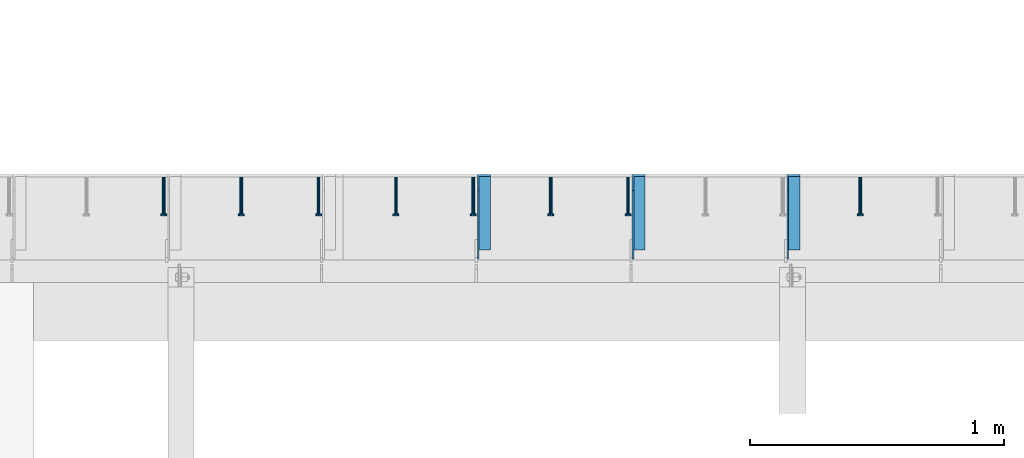
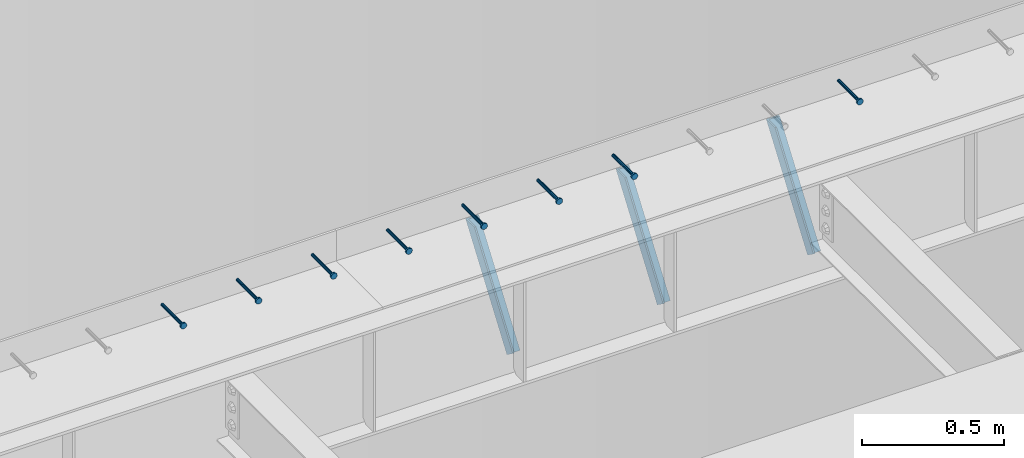
# One storey, part 1356 of 1763: 8 beams, 3 members, 9 elements without a shape of their own.
"""IFC2X3 building model written with IfcOpenShell, lengths in millimetres."""

from ifc_helpers import new_model, si_unit, frame, origin_with_axes, place, context, subcontext, project, spatial, faceted_brep, material, type_object, element, aggregate, save


model = new_model("IFC2X3")

# Units and contexts
model_context = context("Model", 3, precision=1e-05, world=origin_with_axes())
body_context = subcontext(model_context, "Body", "Model", "MODEL_VIEW")
ifc_project = project(units=[si_unit("LENGTHUNIT", "METRE", prefix="MILLI"), si_unit("AREAUNIT", "SQUARE_METRE"), si_unit("VOLUMEUNIT", "CUBIC_METRE"), si_unit("MASSUNIT", "GRAM", prefix="KILO"), si_unit("TIMEUNIT", "SECOND"), si_unit("PLANEANGLEUNIT", "RADIAN"), si_unit("SOLIDANGLEUNIT", "STERADIAN"), si_unit("THERMODYNAMICTEMPERATUREUNIT", "DEGREE_CELSIUS"), si_unit("LUMINOUSINTENSITYUNIT", "LUMEN")], contexts=[model_context])

# Site, building, storey
site_placement = place(None, origin_with_axes())
site = spatial("IfcSite", under=ifc_project, at=site_placement, CompositionType="ELEMENT")
building_placement = place(site_placement, origin_with_axes())
building = spatial("IfcBuilding", under=site, at=building_placement, Name="Undefined", CompositionType="ELEMENT")
storey_placement = place(building_placement, origin_with_axes())
storey = spatial("IfcBuildingStorey", under=building, at=storey_placement, Name="Undefined", CompositionType="ELEMENT", Elevation=0.0)

# Assembly, beam
assembly_1_placement = place(storey_placement, origin_with_axes())
assembly_1 = element("IfcElementAssembly", 1, at=assembly_1_placement, inside=storey, Name="HEADED STUD ANCHOR", AssemblyPlace="NOTDEFINED", PredefinedType="RIGID_FRAME")
ifc_material_1 = material(Name="STEEL/A108")
beam_type = type_object("IfcBeamType", PredefinedType="NOTDEFINED")
beam_1_placement = place(assembly_1_placement, frame((-44317.6747736983, 53984.5250183106, 5264.23140606069), z_axis=(0.0, 0.0, 1.0), x_axis=(0.0, -1.0, 0.0)))
beam_1 = element("IfcBeam", 2, at=beam_1_placement, type_object=beam_type, material=ifc_material_1, Name="HEADED STUD ANCHOR", context=body_context, shape_type="Brep", body=[
    faceted_brep([(0.0, -3.1800000667572, 5.5), (0.0, -5.5, 3.1800000667572), (141.732000000002, -5.5, 3.1800000667572), (141.732000000002, -3.1800000667572, 5.5), (0.0, -6.34999999999491, 1.45519152283669e-11), (141.732000000002, -6.34999990463257, 0.0), (0.0, -5.5, -3.1800000667572), (141.732000000002, -5.5, -3.1800000667572), (0.0, -3.1800000667572, -5.5), (141.732000000002, -3.1800000667572, -5.5), (0.0, 0.0, -6.34999990463257), (141.732000000002, 0.0, -6.34999990463257), (0.0, 3.1800000667572, -5.5), (141.732000000002, 3.1800000667572, -5.5), (0.0, 5.5, -3.1800000667572), (141.732000000002, 5.5, -3.1800000667572), (0.0, 6.34999999999491, -2.91038304567337e-11), (141.732000000002, 6.34999990463257, 0.0), (0.0, 5.5, 3.1800000667572), (141.732000000002, 5.5, 3.1800000667572), (0.0, 3.1800000667572, 5.5), (141.732000000002, 3.1800000667572, 5.5), (0.0, 0.0, 6.34999990463257), (141.732000000002, 0.0, 6.34999990463257), (144.780000000001, -10.9899997711182, 6.34999990463257), (144.780000000001, -6.34000015258789, 10.9899997711182), (144.780000000001, -12.6999998092651, 0.0), (144.780000000001, -10.9899997711182, -6.34999990463257), (144.780000000001, -6.34000015258789, -10.9899997711182), (144.780000000001, 0.0, -12.6899995803833), (144.780000000001, 6.34000015258789, -10.9899997711182), (144.780000000001, 10.9899997711182, -6.34999990463257), (144.780000000001, 12.6999998092651, 0.0), (144.780000000001, 10.9899997711182, 6.34999990463257), (144.780000000001, 6.34000015258789, 10.9899997711182), (144.780000000001, 0.0, 12.6899995803833), (152.400000000001, -10.9899997711182, 6.34999990463257), (152.400000000001, -6.34000015258789, 10.9899997711182), (152.400000000001, -12.6999998092651, 0.0), (152.400000000001, -10.9899997711182, -6.34999990463257), (152.400000000001, -6.34000015258789, -10.9899997711182), (152.400000000001, 0.0, -12.6899995803833), (152.400000000001, 6.34000015258789, -10.9899997711182), (152.400000000001, 10.9899997711182, -6.34999990463257), (152.400000000001, 12.6999998092651, 0.0), (152.400000000001, 10.9899997711182, 6.34999990463257), (152.400000000001, 6.34000015258789, 10.9899997711182), (152.400000000001, 0.0, 12.6899995803833)], [[[0, 1, 2, 3]], [[1, 4, 5, 2]], [[4, 6, 7, 5]], [[6, 8, 9, 7]], [[8, 10, 11, 9]], [[10, 12, 13, 11]], [[12, 14, 15, 13]], [[14, 16, 17, 15]], [[16, 18, 19, 17]], [[18, 20, 21, 19]], [[20, 22, 23, 21]], [[22, 0, 3, 23]], [[22, 20, 18, 16, 14, 12, 10, 8, 6, 4, 1, 0]], [[3, 2, 24, 25]], [[2, 5, 26, 24]], [[5, 7, 27, 26]], [[7, 9, 28, 27]], [[9, 11, 29, 28]], [[11, 13, 30, 29]], [[13, 15, 31, 30]], [[15, 17, 32, 31]], [[17, 19, 33, 32]], [[19, 21, 34, 33]], [[21, 23, 35, 34]], [[23, 3, 25, 35]], [[25, 24, 36, 37]], [[24, 26, 38, 36]], [[26, 27, 39, 38]], [[27, 28, 40, 39]], [[28, 29, 41, 40]], [[29, 30, 42, 41]], [[30, 31, 43, 42]], [[31, 32, 44, 43]], [[32, 33, 45, 44]], [[33, 34, 46, 45]], [[34, 35, 47, 46]], [[35, 25, 37, 47]], [[38, 39, 40, 41, 42, 43, 44, 45, 46, 47, 37, 36]]]),
])
aggregate(assembly_1, [beam_1])

assembly_2_placement = place(storey_placement, origin_with_axes())
assembly_2 = element("IfcElementAssembly", 3, at=assembly_2_placement, inside=storey, Name="HEADED STUD ANCHOR", AssemblyPlace="NOTDEFINED", PredefinedType="RIGID_FRAME")
beam_2_placement = place(assembly_2_placement, frame((-45232.0747736983, 53984.5250183106, 5264.23140606069), z_axis=(0.0, 0.0, 1.0), x_axis=(0.0, -1.0, 0.0)))
beam_2 = element("IfcBeam", 4, at=beam_2_placement, type_object=beam_type, material=ifc_material_1, Name="HEADED STUD ANCHOR", context=body_context, shape_type="Brep", body=[
    faceted_brep([(0.0, -3.1800000667572, 5.5), (0.0, -5.5, 3.1800000667572), (141.732000000002, -5.5, 3.1800000667572), (141.732000000002, -3.1800000667572, 5.5), (0.0, -6.34999999999491, 1.45519152283669e-11), (141.732000000002, -6.34999990463257, 0.0), (0.0, -5.5, -3.1800000667572), (141.732000000002, -5.5, -3.1800000667572), (0.0, -3.1800000667572, -5.5), (141.732000000002, -3.1800000667572, -5.5), (0.0, 0.0, -6.34999990463257), (141.732000000002, 0.0, -6.34999990463257), (0.0, 3.1800000667572, -5.5), (141.732000000002, 3.1800000667572, -5.5), (0.0, 5.5, -3.1800000667572), (141.732000000002, 5.5, -3.1800000667572), (0.0, 6.34999999999491, -2.91038304567337e-11), (141.732000000002, 6.34999990463257, 0.0), (0.0, 5.5, 3.1800000667572), (141.732000000002, 5.5, 3.1800000667572), (0.0, 3.1800000667572, 5.5), (141.732000000002, 3.1800000667572, 5.5), (0.0, 0.0, 6.34999990463257), (141.732000000002, 0.0, 6.34999990463257), (144.780000000001, -10.9899997711182, 6.34999990463257), (144.780000000001, -6.34000015258789, 10.9899997711182), (144.780000000001, -12.6999998092651, 0.0), (144.780000000001, -10.9899997711182, -6.34999990463257), (144.780000000001, -6.34000015258789, -10.9899997711182), (144.780000000001, 0.0, -12.6899995803833), (144.780000000001, 6.34000015258789, -10.9899997711182), (144.780000000001, 10.9899997711182, -6.34999990463257), (144.780000000001, 12.6999998092651, 0.0), (144.780000000001, 10.9899997711182, 6.34999990463257), (144.780000000001, 6.34000015258789, 10.9899997711182), (144.780000000001, 0.0, 12.6899995803833), (152.400000000001, -10.9899997711182, 6.34999990463257), (152.400000000001, -6.34000015258789, 10.9899997711182), (152.400000000001, -12.6999998092651, 0.0), (152.400000000001, -10.9899997711182, -6.34999990463257), (152.400000000001, -6.34000015258789, -10.9899997711182), (152.400000000001, 0.0, -12.6899995803833), (152.400000000001, 6.34000015258789, -10.9899997711182), (152.400000000001, 10.9899997711182, -6.34999990463257), (152.400000000001, 12.6999998092651, 0.0), (152.400000000001, 10.9899997711182, 6.34999990463257), (152.400000000001, 6.34000015258789, 10.9899997711182), (152.400000000001, 0.0, 12.6899995803833)], [[[0, 1, 2, 3]], [[1, 4, 5, 2]], [[4, 6, 7, 5]], [[6, 8, 9, 7]], [[8, 10, 11, 9]], [[10, 12, 13, 11]], [[12, 14, 15, 13]], [[14, 16, 17, 15]], [[16, 18, 19, 17]], [[18, 20, 21, 19]], [[20, 22, 23, 21]], [[22, 0, 3, 23]], [[22, 20, 18, 16, 14, 12, 10, 8, 6, 4, 1, 0]], [[3, 2, 24, 25]], [[2, 5, 26, 24]], [[5, 7, 27, 26]], [[7, 9, 28, 27]], [[9, 11, 29, 28]], [[11, 13, 30, 29]], [[13, 15, 31, 30]], [[15, 17, 32, 31]], [[17, 19, 33, 32]], [[19, 21, 34, 33]], [[21, 23, 35, 34]], [[23, 3, 25, 35]], [[25, 24, 36, 37]], [[24, 26, 38, 36]], [[26, 27, 39, 38]], [[27, 28, 40, 39]], [[28, 29, 41, 40]], [[29, 30, 42, 41]], [[30, 31, 43, 42]], [[31, 32, 44, 43]], [[32, 33, 45, 44]], [[33, 34, 46, 45]], [[34, 35, 47, 46]], [[35, 25, 37, 47]], [[38, 39, 40, 41, 42, 43, 44, 45, 46, 47, 37, 36]]]),
])
aggregate(assembly_2, [beam_2])

assembly_3_placement = place(storey_placement, origin_with_axes())
assembly_3 = element("IfcElementAssembly", 5, at=assembly_3_placement, inside=storey, Name="HEADED STUD ANCHOR", AssemblyPlace="NOTDEFINED", PredefinedType="RIGID_FRAME")
beam_3_placement = place(assembly_3_placement, frame((-45536.8747736983, 53984.5250183106, 5264.23140606069), z_axis=(0.0, 0.0, 1.0), x_axis=(0.0, -1.0, 0.0)))
beam_3 = element("IfcBeam", 6, at=beam_3_placement, type_object=beam_type, material=ifc_material_1, Name="HEADED STUD ANCHOR", context=body_context, shape_type="Brep", body=[
    faceted_brep([(0.0, -3.1800000667572, 5.5), (0.0, -5.5, 3.1800000667572), (141.732000000002, -5.5, 3.1800000667572), (141.732000000002, -3.1800000667572, 5.5), (0.0, -6.34999999999491, 1.45519152283669e-11), (141.732000000002, -6.34999990463257, 0.0), (0.0, -5.5, -3.1800000667572), (141.732000000002, -5.5, -3.1800000667572), (0.0, -3.1800000667572, -5.5), (141.732000000002, -3.1800000667572, -5.5), (0.0, 0.0, -6.34999990463257), (141.732000000002, 0.0, -6.34999990463257), (0.0, 3.1800000667572, -5.5), (141.732000000002, 3.1800000667572, -5.5), (0.0, 5.5, -3.1800000667572), (141.732000000002, 5.5, -3.1800000667572), (0.0, 6.34999999999491, -2.91038304567337e-11), (141.732000000002, 6.34999990463257, 0.0), (0.0, 5.5, 3.1800000667572), (141.732000000002, 5.5, 3.1800000667572), (0.0, 3.1800000667572, 5.5), (141.732000000002, 3.1800000667572, 5.5), (0.0, 0.0, 6.34999990463257), (141.732000000002, 0.0, 6.34999990463257), (144.780000000001, -10.9899997711182, 6.34999990463257), (144.780000000001, -6.34000015258789, 10.9899997711182), (144.780000000001, -12.6999998092651, 0.0), (144.780000000001, -10.9899997711182, -6.34999990463257), (144.780000000001, -6.34000015258789, -10.9899997711182), (144.780000000001, 0.0, -12.6899995803833), (144.780000000001, 6.34000015258789, -10.9899997711182), (144.780000000001, 10.9899997711182, -6.34999990463257), (144.780000000001, 12.6999998092651, 0.0), (144.780000000001, 10.9899997711182, 6.34999990463257), (144.780000000001, 6.34000015258789, 10.9899997711182), (144.780000000001, 0.0, 12.6899995803833), (152.400000000001, -10.9899997711182, 6.34999990463257), (152.400000000001, -6.34000015258789, 10.9899997711182), (152.400000000001, -12.6999998092651, 0.0), (152.400000000001, -10.9899997711182, -6.34999990463257), (152.400000000001, -6.34000015258789, -10.9899997711182), (152.400000000001, 0.0, -12.6899995803833), (152.400000000001, 6.34000015258789, -10.9899997711182), (152.400000000001, 10.9899997711182, -6.34999990463257), (152.400000000001, 12.6999998092651, 0.0), (152.400000000001, 10.9899997711182, 6.34999990463257), (152.400000000001, 6.34000015258789, 10.9899997711182), (152.400000000001, 0.0, 12.6899995803833)], [[[0, 1, 2, 3]], [[1, 4, 5, 2]], [[4, 6, 7, 5]], [[6, 8, 9, 7]], [[8, 10, 11, 9]], [[10, 12, 13, 11]], [[12, 14, 15, 13]], [[14, 16, 17, 15]], [[16, 18, 19, 17]], [[18, 20, 21, 19]], [[20, 22, 23, 21]], [[22, 0, 3, 23]], [[22, 20, 18, 16, 14, 12, 10, 8, 6, 4, 1, 0]], [[3, 2, 24, 25]], [[2, 5, 26, 24]], [[5, 7, 27, 26]], [[7, 9, 28, 27]], [[9, 11, 29, 28]], [[11, 13, 30, 29]], [[13, 15, 31, 30]], [[15, 17, 32, 31]], [[17, 19, 33, 32]], [[19, 21, 34, 33]], [[21, 23, 35, 34]], [[23, 3, 25, 35]], [[25, 24, 36, 37]], [[24, 26, 38, 36]], [[26, 27, 39, 38]], [[27, 28, 40, 39]], [[28, 29, 41, 40]], [[29, 30, 42, 41]], [[30, 31, 43, 42]], [[31, 32, 44, 43]], [[32, 33, 45, 44]], [[33, 34, 46, 45]], [[34, 35, 47, 46]], [[35, 25, 37, 47]], [[38, 39, 40, 41, 42, 43, 44, 45, 46, 47, 37, 36]]]),
])
aggregate(assembly_3, [beam_3])

assembly_4_placement = place(storey_placement, origin_with_axes())
assembly_4 = element("IfcElementAssembly", 7, at=assembly_4_placement, inside=storey, Name="HEADED STUD ANCHOR", AssemblyPlace="NOTDEFINED", PredefinedType="RIGID_FRAME")
beam_4_placement = place(assembly_4_placement, frame((-45841.6747736983, 53984.5250183106, 5264.23140606069), z_axis=(0.0, 0.0, 1.0), x_axis=(0.0, -1.0, 0.0)))
beam_4 = element("IfcBeam", 8, at=beam_4_placement, type_object=beam_type, material=ifc_material_1, Name="HEADED STUD ANCHOR", context=body_context, shape_type="Brep", body=[
    faceted_brep([(0.0, -3.1800000667572, 5.5), (0.0, -5.5, 3.1800000667572), (141.732000000002, -5.5, 3.1800000667572), (141.732000000002, -3.1800000667572, 5.5), (0.0, -6.34999999999491, 1.45519152283669e-11), (141.732000000002, -6.34999990463257, 0.0), (0.0, -5.5, -3.1800000667572), (141.732000000002, -5.5, -3.1800000667572), (0.0, -3.1800000667572, -5.5), (141.732000000002, -3.1800000667572, -5.5), (0.0, 0.0, -6.34999990463257), (141.732000000002, 0.0, -6.34999990463257), (0.0, 3.1800000667572, -5.5), (141.732000000002, 3.1800000667572, -5.5), (0.0, 5.5, -3.1800000667572), (141.732000000002, 5.5, -3.1800000667572), (0.0, 6.34999999999491, -2.91038304567337e-11), (141.732000000002, 6.34999990463257, 0.0), (0.0, 5.5, 3.1800000667572), (141.732000000002, 5.5, 3.1800000667572), (0.0, 3.1800000667572, 5.5), (141.732000000002, 3.1800000667572, 5.5), (0.0, 0.0, 6.34999990463257), (141.732000000002, 0.0, 6.34999990463257), (144.780000000001, -10.9899997711182, 6.34999990463257), (144.780000000001, -6.34000015258789, 10.9899997711182), (144.780000000001, -12.6999998092651, 0.0), (144.780000000001, -10.9899997711182, -6.34999990463257), (144.780000000001, -6.34000015258789, -10.9899997711182), (144.780000000001, 0.0, -12.6899995803833), (144.780000000001, 6.34000015258789, -10.9899997711182), (144.780000000001, 10.9899997711182, -6.34999990463257), (144.780000000001, 12.6999998092651, 0.0), (144.780000000001, 10.9899997711182, 6.34999990463257), (144.780000000001, 6.34000015258789, 10.9899997711182), (144.780000000001, 0.0, 12.6899995803833), (152.400000000001, -10.9899997711182, 6.34999990463257), (152.400000000001, -6.34000015258789, 10.9899997711182), (152.400000000001, -12.6999998092651, 0.0), (152.400000000001, -10.9899997711182, -6.34999990463257), (152.400000000001, -6.34000015258789, -10.9899997711182), (152.400000000001, 0.0, -12.6899995803833), (152.400000000001, 6.34000015258789, -10.9899997711182), (152.400000000001, 10.9899997711182, -6.34999990463257), (152.400000000001, 12.6999998092651, 0.0), (152.400000000001, 10.9899997711182, 6.34999990463257), (152.400000000001, 6.34000015258789, 10.9899997711182), (152.400000000001, 0.0, 12.6899995803833)], [[[0, 1, 2, 3]], [[1, 4, 5, 2]], [[4, 6, 7, 5]], [[6, 8, 9, 7]], [[8, 10, 11, 9]], [[10, 12, 13, 11]], [[12, 14, 15, 13]], [[14, 16, 17, 15]], [[16, 18, 19, 17]], [[18, 20, 21, 19]], [[20, 22, 23, 21]], [[22, 0, 3, 23]], [[22, 20, 18, 16, 14, 12, 10, 8, 6, 4, 1, 0]], [[3, 2, 24, 25]], [[2, 5, 26, 24]], [[5, 7, 27, 26]], [[7, 9, 28, 27]], [[9, 11, 29, 28]], [[11, 13, 30, 29]], [[13, 15, 31, 30]], [[15, 17, 32, 31]], [[17, 19, 33, 32]], [[19, 21, 34, 33]], [[21, 23, 35, 34]], [[23, 3, 25, 35]], [[25, 24, 36, 37]], [[24, 26, 38, 36]], [[26, 27, 39, 38]], [[27, 28, 40, 39]], [[28, 29, 41, 40]], [[29, 30, 42, 41]], [[30, 31, 43, 42]], [[31, 32, 44, 43]], [[32, 33, 45, 44]], [[33, 34, 46, 45]], [[34, 35, 47, 46]], [[35, 25, 37, 47]], [[38, 39, 40, 41, 42, 43, 44, 45, 46, 47, 37, 36]]]),
])
aggregate(assembly_4, [beam_4])

assembly_5_placement = place(storey_placement, origin_with_axes())
assembly_5 = element("IfcElementAssembly", 9, at=assembly_5_placement, inside=storey, Name="HEADED STUD ANCHOR", AssemblyPlace="NOTDEFINED", PredefinedType="RIGID_FRAME")
beam_5_placement = place(assembly_5_placement, frame((-46146.4747736983, 53984.5250183106, 5264.23140606069), z_axis=(0.0, 0.0, 1.0), x_axis=(0.0, -1.0, 0.0)))
beam_5 = element("IfcBeam", 10, at=beam_5_placement, type_object=beam_type, material=ifc_material_1, Name="HEADED STUD ANCHOR", context=body_context, shape_type="Brep", body=[
    faceted_brep([(0.0, -3.1800000667572, 5.5), (0.0, -5.5, 3.1800000667572), (141.732000000002, -5.5, 3.1800000667572), (141.732000000002, -3.1800000667572, 5.5), (0.0, -6.34999999999491, 1.45519152283669e-11), (141.732000000002, -6.34999990463257, 0.0), (0.0, -5.5, -3.1800000667572), (141.732000000002, -5.5, -3.1800000667572), (0.0, -3.1800000667572, -5.5), (141.732000000002, -3.1800000667572, -5.5), (0.0, 0.0, -6.34999990463257), (141.732000000002, 0.0, -6.34999990463257), (0.0, 3.1800000667572, -5.5), (141.732000000002, 3.1800000667572, -5.5), (0.0, 5.5, -3.1800000667572), (141.732000000002, 5.5, -3.1800000667572), (0.0, 6.34999999999491, -2.91038304567337e-11), (141.732000000002, 6.34999990463257, 0.0), (0.0, 5.5, 3.1800000667572), (141.732000000002, 5.5, 3.1800000667572), (0.0, 3.1800000667572, 5.5), (141.732000000002, 3.1800000667572, 5.5), (0.0, 0.0, 6.34999990463257), (141.732000000002, 0.0, 6.34999990463257), (144.780000000001, -10.9899997711182, 6.34999990463257), (144.780000000001, -6.34000015258789, 10.9899997711182), (144.780000000001, -12.6999998092651, 0.0), (144.780000000001, -10.9899997711182, -6.34999990463257), (144.780000000001, -6.34000015258789, -10.9899997711182), (144.780000000001, 0.0, -12.6899995803833), (144.780000000001, 6.34000015258789, -10.9899997711182), (144.780000000001, 10.9899997711182, -6.34999990463257), (144.780000000001, 12.6999998092651, 0.0), (144.780000000001, 10.9899997711182, 6.34999990463257), (144.780000000001, 6.34000015258789, 10.9899997711182), (144.780000000001, 0.0, 12.6899995803833), (152.400000000001, -10.9899997711182, 6.34999990463257), (152.400000000001, -6.34000015258789, 10.9899997711182), (152.400000000001, -12.6999998092651, 0.0), (152.400000000001, -10.9899997711182, -6.34999990463257), (152.400000000001, -6.34000015258789, -10.9899997711182), (152.400000000001, 0.0, -12.6899995803833), (152.400000000001, 6.34000015258789, -10.9899997711182), (152.400000000001, 10.9899997711182, -6.34999990463257), (152.400000000001, 12.6999998092651, 0.0), (152.400000000001, 10.9899997711182, 6.34999990463257), (152.400000000001, 6.34000015258789, 10.9899997711182), (152.400000000001, 0.0, 12.6899995803833)], [[[0, 1, 2, 3]], [[1, 4, 5, 2]], [[4, 6, 7, 5]], [[6, 8, 9, 7]], [[8, 10, 11, 9]], [[10, 12, 13, 11]], [[12, 14, 15, 13]], [[14, 16, 17, 15]], [[16, 18, 19, 17]], [[18, 20, 21, 19]], [[20, 22, 23, 21]], [[22, 0, 3, 23]], [[22, 20, 18, 16, 14, 12, 10, 8, 6, 4, 1, 0]], [[3, 2, 24, 25]], [[2, 5, 26, 24]], [[5, 7, 27, 26]], [[7, 9, 28, 27]], [[9, 11, 29, 28]], [[11, 13, 30, 29]], [[13, 15, 31, 30]], [[15, 17, 32, 31]], [[17, 19, 33, 32]], [[19, 21, 34, 33]], [[21, 23, 35, 34]], [[23, 3, 25, 35]], [[25, 24, 36, 37]], [[24, 26, 38, 36]], [[26, 27, 39, 38]], [[27, 28, 40, 39]], [[28, 29, 41, 40]], [[29, 30, 42, 41]], [[30, 31, 43, 42]], [[31, 32, 44, 43]], [[32, 33, 45, 44]], [[33, 34, 46, 45]], [[34, 35, 47, 46]], [[35, 25, 37, 47]], [[38, 39, 40, 41, 42, 43, 44, 45, 46, 47, 37, 36]]]),
])
aggregate(assembly_5, [beam_5])

assembly_6_placement = place(storey_placement, origin_with_axes())
assembly_6 = element("IfcElementAssembly", 11, at=assembly_6_placement, inside=storey, Name="HEADED STUD ANCHOR", AssemblyPlace="NOTDEFINED", PredefinedType="RIGID_FRAME")
beam_6_placement = place(assembly_6_placement, frame((-46451.2747736983, 53984.5250183106, 5264.23140606069), z_axis=(0.0, 0.0, 1.0), x_axis=(0.0, -1.0, 0.0)))
beam_6 = element("IfcBeam", 12, at=beam_6_placement, type_object=beam_type, material=ifc_material_1, Name="HEADED STUD ANCHOR", context=body_context, shape_type="Brep", body=[
    faceted_brep([(0.0, -3.1800000667572, 5.5), (0.0, -5.5, 3.1800000667572), (141.732000000002, -5.5, 3.1800000667572), (141.732000000002, -3.1800000667572, 5.5), (0.0, -6.34999999999491, 1.45519152283669e-11), (141.732000000002, -6.34999990463257, 0.0), (0.0, -5.5, -3.1800000667572), (141.732000000002, -5.5, -3.1800000667572), (0.0, -3.1800000667572, -5.5), (141.732000000002, -3.1800000667572, -5.5), (0.0, 0.0, -6.34999990463257), (141.732000000002, 0.0, -6.34999990463257), (0.0, 3.1800000667572, -5.5), (141.732000000002, 3.1800000667572, -5.5), (0.0, 5.5, -3.1800000667572), (141.732000000002, 5.5, -3.1800000667572), (0.0, 6.34999999999491, -2.91038304567337e-11), (141.732000000002, 6.34999990463257, 0.0), (0.0, 5.5, 3.1800000667572), (141.732000000002, 5.5, 3.1800000667572), (0.0, 3.1800000667572, 5.5), (141.732000000002, 3.1800000667572, 5.5), (0.0, 0.0, 6.34999990463257), (141.732000000002, 0.0, 6.34999990463257), (144.780000000001, -10.9899997711182, 6.34999990463257), (144.780000000001, -6.34000015258789, 10.9899997711182), (144.780000000001, -12.6999998092651, 0.0), (144.780000000001, -10.9899997711182, -6.34999990463257), (144.780000000001, -6.34000015258789, -10.9899997711182), (144.780000000001, 0.0, -12.6899995803833), (144.780000000001, 6.34000015258789, -10.9899997711182), (144.780000000001, 10.9899997711182, -6.34999990463257), (144.780000000001, 12.6999998092651, 0.0), (144.780000000001, 10.9899997711182, 6.34999990463257), (144.780000000001, 6.34000015258789, 10.9899997711182), (144.780000000001, 0.0, 12.6899995803833), (152.400000000001, -10.9899997711182, 6.34999990463257), (152.400000000001, -6.34000015258789, 10.9899997711182), (152.400000000001, -12.6999998092651, 0.0), (152.400000000001, -10.9899997711182, -6.34999990463257), (152.400000000001, -6.34000015258789, -10.9899997711182), (152.400000000001, 0.0, -12.6899995803833), (152.400000000001, 6.34000015258789, -10.9899997711182), (152.400000000001, 10.9899997711182, -6.34999990463257), (152.400000000001, 12.6999998092651, 0.0), (152.400000000001, 10.9899997711182, 6.34999990463257), (152.400000000001, 6.34000015258789, 10.9899997711182), (152.400000000001, 0.0, 12.6899995803833)], [[[0, 1, 2, 3]], [[1, 4, 5, 2]], [[4, 6, 7, 5]], [[6, 8, 9, 7]], [[8, 10, 11, 9]], [[10, 12, 13, 11]], [[12, 14, 15, 13]], [[14, 16, 17, 15]], [[16, 18, 19, 17]], [[18, 20, 21, 19]], [[20, 22, 23, 21]], [[22, 0, 3, 23]], [[22, 20, 18, 16, 14, 12, 10, 8, 6, 4, 1, 0]], [[3, 2, 24, 25]], [[2, 5, 26, 24]], [[5, 7, 27, 26]], [[7, 9, 28, 27]], [[9, 11, 29, 28]], [[11, 13, 30, 29]], [[13, 15, 31, 30]], [[15, 17, 32, 31]], [[17, 19, 33, 32]], [[19, 21, 34, 33]], [[21, 23, 35, 34]], [[23, 3, 25, 35]], [[25, 24, 36, 37]], [[24, 26, 38, 36]], [[26, 27, 39, 38]], [[27, 28, 40, 39]], [[28, 29, 41, 40]], [[29, 30, 42, 41]], [[30, 31, 43, 42]], [[31, 32, 44, 43]], [[32, 33, 45, 44]], [[33, 34, 46, 45]], [[34, 35, 47, 46]], [[35, 25, 37, 47]], [[38, 39, 40, 41, 42, 43, 44, 45, 46, 47, 37, 36]]]),
])
aggregate(assembly_6, [beam_6])

assembly_7_placement = place(storey_placement, origin_with_axes())
assembly_7 = element("IfcElementAssembly", 13, at=assembly_7_placement, inside=storey, Name="HEADED STUD ANCHOR", AssemblyPlace="NOTDEFINED", PredefinedType="RIGID_FRAME")
beam_7_placement = place(assembly_7_placement, frame((-46756.0747736983, 53984.5250183106, 5264.23140606069), z_axis=(0.0, 0.0, 1.0), x_axis=(0.0, -1.0, 0.0)))
beam_7 = element("IfcBeam", 14, at=beam_7_placement, type_object=beam_type, material=ifc_material_1, Name="HEADED STUD ANCHOR", context=body_context, shape_type="Brep", body=[
    faceted_brep([(0.0, -3.1800000667572, 5.5), (0.0, -5.5, 3.1800000667572), (141.732000000002, -5.5, 3.1800000667572), (141.732000000002, -3.1800000667572, 5.5), (0.0, -6.34999999999491, 1.45519152283669e-11), (141.732000000002, -6.34999990463257, 0.0), (0.0, -5.5, -3.1800000667572), (141.732000000002, -5.5, -3.1800000667572), (0.0, -3.1800000667572, -5.5), (141.732000000002, -3.1800000667572, -5.5), (0.0, 0.0, -6.34999990463257), (141.732000000002, 0.0, -6.34999990463257), (0.0, 3.1800000667572, -5.5), (141.732000000002, 3.1800000667572, -5.5), (0.0, 5.5, -3.1800000667572), (141.732000000002, 5.5, -3.1800000667572), (0.0, 6.34999999999491, -2.91038304567337e-11), (141.732000000002, 6.34999990463257, 0.0), (0.0, 5.5, 3.1800000667572), (141.732000000002, 5.5, 3.1800000667572), (0.0, 3.1800000667572, 5.5), (141.732000000002, 3.1800000667572, 5.5), (0.0, 0.0, 6.34999990463257), (141.732000000002, 0.0, 6.34999990463257), (144.780000000001, -10.9899997711182, 6.34999990463257), (144.780000000001, -6.34000015258789, 10.9899997711182), (144.780000000001, -12.6999998092651, 0.0), (144.780000000001, -10.9899997711182, -6.34999990463257), (144.780000000001, -6.34000015258789, -10.9899997711182), (144.780000000001, 0.0, -12.6899995803833), (144.780000000001, 6.34000015258789, -10.9899997711182), (144.780000000001, 10.9899997711182, -6.34999990463257), (144.780000000001, 12.6999998092651, 0.0), (144.780000000001, 10.9899997711182, 6.34999990463257), (144.780000000001, 6.34000015258789, 10.9899997711182), (144.780000000001, 0.0, 12.6899995803833), (152.400000000001, -10.9899997711182, 6.34999990463257), (152.400000000001, -6.34000015258789, 10.9899997711182), (152.400000000001, -12.6999998092651, 0.0), (152.400000000001, -10.9899997711182, -6.34999990463257), (152.400000000001, -6.34000015258789, -10.9899997711182), (152.400000000001, 0.0, -12.6899995803833), (152.400000000001, 6.34000015258789, -10.9899997711182), (152.400000000001, 10.9899997711182, -6.34999990463257), (152.400000000001, 12.6999998092651, 0.0), (152.400000000001, 10.9899997711182, 6.34999990463257), (152.400000000001, 6.34000015258789, 10.9899997711182), (152.400000000001, 0.0, 12.6899995803833)], [[[0, 1, 2, 3]], [[1, 4, 5, 2]], [[4, 6, 7, 5]], [[6, 8, 9, 7]], [[8, 10, 11, 9]], [[10, 12, 13, 11]], [[12, 14, 15, 13]], [[14, 16, 17, 15]], [[16, 18, 19, 17]], [[18, 20, 21, 19]], [[20, 22, 23, 21]], [[22, 0, 3, 23]], [[22, 20, 18, 16, 14, 12, 10, 8, 6, 4, 1, 0]], [[3, 2, 24, 25]], [[2, 5, 26, 24]], [[5, 7, 27, 26]], [[7, 9, 28, 27]], [[9, 11, 29, 28]], [[11, 13, 30, 29]], [[13, 15, 31, 30]], [[15, 17, 32, 31]], [[17, 19, 33, 32]], [[19, 21, 34, 33]], [[21, 23, 35, 34]], [[23, 3, 25, 35]], [[25, 24, 36, 37]], [[24, 26, 38, 36]], [[26, 27, 39, 38]], [[27, 28, 40, 39]], [[28, 29, 41, 40]], [[29, 30, 42, 41]], [[30, 31, 43, 42]], [[31, 32, 44, 43]], [[32, 33, 45, 44]], [[33, 34, 46, 45]], [[34, 35, 47, 46]], [[35, 25, 37, 47]], [[38, 39, 40, 41, 42, 43, 44, 45, 46, 47, 37, 36]]]),
])
aggregate(assembly_7, [beam_7])

assembly_8_placement = place(storey_placement, origin_with_axes())
assembly_8 = element("IfcElementAssembly", 15, at=assembly_8_placement, inside=storey, Name="HEADED STUD ANCHOR", AssemblyPlace="NOTDEFINED", PredefinedType="RIGID_FRAME")
beam_8_placement = place(assembly_8_placement, frame((-47060.8747736983, 53984.5250183106, 5264.23140606069), z_axis=(0.0, 0.0, 1.0), x_axis=(0.0, -1.0, 0.0)))
beam_8 = element("IfcBeam", 16, at=beam_8_placement, type_object=beam_type, material=ifc_material_1, Name="HEADED STUD ANCHOR", context=body_context, shape_type="Brep", body=[
    faceted_brep([(0.0, -3.1800000667572, 5.5), (0.0, -5.5, 3.1800000667572), (141.732000000002, -5.5, 3.1800000667572), (141.732000000002, -3.1800000667572, 5.5), (0.0, -6.34999999999491, 1.45519152283669e-11), (141.732000000002, -6.34999990463257, 0.0), (0.0, -5.5, -3.1800000667572), (141.732000000002, -5.5, -3.1800000667572), (0.0, -3.1800000667572, -5.5), (141.732000000002, -3.1800000667572, -5.5), (0.0, 0.0, -6.34999990463257), (141.732000000002, 0.0, -6.34999990463257), (0.0, 3.1800000667572, -5.5), (141.732000000002, 3.1800000667572, -5.5), (0.0, 5.5, -3.1800000667572), (141.732000000002, 5.5, -3.1800000667572), (0.0, 6.34999999999491, -2.91038304567337e-11), (141.732000000002, 6.34999990463257, 0.0), (0.0, 5.5, 3.1800000667572), (141.732000000002, 5.5, 3.1800000667572), (0.0, 3.1800000667572, 5.5), (141.732000000002, 3.1800000667572, 5.5), (0.0, 0.0, 6.34999990463257), (141.732000000002, 0.0, 6.34999990463257), (144.780000000001, -10.9899997711182, 6.34999990463257), (144.780000000001, -6.34000015258789, 10.9899997711182), (144.780000000001, -12.6999998092651, 0.0), (144.780000000001, -10.9899997711182, -6.34999990463257), (144.780000000001, -6.34000015258789, -10.9899997711182), (144.780000000001, 0.0, -12.6899995803833), (144.780000000001, 6.34000015258789, -10.9899997711182), (144.780000000001, 10.9899997711182, -6.34999990463257), (144.780000000001, 12.6999998092651, 0.0), (144.780000000001, 10.9899997711182, 6.34999990463257), (144.780000000001, 6.34000015258789, 10.9899997711182), (144.780000000001, 0.0, 12.6899995803833), (152.400000000001, -10.9899997711182, 6.34999990463257), (152.400000000001, -6.34000015258789, 10.9899997711182), (152.400000000001, -12.6999998092651, 0.0), (152.400000000001, -10.9899997711182, -6.34999990463257), (152.400000000001, -6.34000015258789, -10.9899997711182), (152.400000000001, 0.0, -12.6899995803833), (152.400000000001, 6.34000015258789, -10.9899997711182), (152.400000000001, 10.9899997711182, -6.34999990463257), (152.400000000001, 12.6999998092651, 0.0), (152.400000000001, 10.9899997711182, 6.34999990463257), (152.400000000001, 6.34000015258789, 10.9899997711182), (152.400000000001, 0.0, 12.6899995803833)], [[[0, 1, 2, 3]], [[1, 4, 5, 2]], [[4, 6, 7, 5]], [[6, 8, 9, 7]], [[8, 10, 11, 9]], [[10, 12, 13, 11]], [[12, 14, 15, 13]], [[14, 16, 17, 15]], [[16, 18, 19, 17]], [[18, 20, 21, 19]], [[20, 22, 23, 21]], [[22, 0, 3, 23]], [[22, 20, 18, 16, 14, 12, 10, 8, 6, 4, 1, 0]], [[3, 2, 24, 25]], [[2, 5, 26, 24]], [[5, 7, 27, 26]], [[7, 9, 28, 27]], [[9, 11, 29, 28]], [[11, 13, 30, 29]], [[13, 15, 31, 30]], [[15, 17, 32, 31]], [[17, 19, 33, 32]], [[19, 21, 34, 33]], [[21, 23, 35, 34]], [[23, 3, 25, 35]], [[25, 24, 36, 37]], [[24, 26, 38, 36]], [[26, 27, 39, 38]], [[27, 28, 40, 39]], [[28, 29, 41, 40]], [[29, 30, 42, 41]], [[30, 31, 43, 42]], [[31, 32, 44, 43]], [[32, 33, 45, 44]], [[33, 34, 46, 45]], [[34, 35, 47, 46]], [[35, 25, 37, 47]], [[38, 39, 40, 41, 42, 43, 44, 45, 46, 47, 37, 36]]]),
])
aggregate(assembly_8, [beam_8])

# Assembly, members
assembly_9_placement = place(storey_placement, origin_with_axes())
assembly_9 = element("IfcElementAssembly", 17, at=assembly_9_placement, inside=storey, Name="BEAM", AssemblyPlace="NOTDEFINED", PredefinedType="RIGID_FRAME")
ifc_material_2 = material(Name="STEEL/A36")
member_type = type_object("IfcMemberType", Name="L2X2X1/4", PredefinedType="NOTDEFINED")
member_1_placement = place(assembly_9_placement, frame((-44580.6044734054, 53682.708383399, 4801.55161052505), z_axis=(0.0, -0.814117947745209, 0.580699549818259), x_axis=(0.0, 0.58069954981826, 0.814117947745209)))
member_1 = element("IfcMember", 18, at=member_1_placement, type_object=member_type, material=ifc_material_2, Name="ANGLE", ObjectType="L2X2X1/4", context=body_context, shape_type="Brep", body=[
    faceted_brep([(-1.45519152283669e-11, 25.4000000000015, -25.3999999999869), (1.45519152283669e-11, 25.4000000000015, 25.3999999999796), (464.304493432646, 25.4000000000015, 25.3999999991429), (500.539460322936, 25.4000000000015, -25.4000000009546), (1.45519152283669e-11, 19.0499999999993, 25.3999999999796), (464.304493432646, 19.0500000000029, 25.3999999991429), (-7.27595761418343e-12, 19.0499999999993, -19.0499999999956), (496.010089461648, 19.0500000000029, -19.0500000009415), (-7.27595761418343e-12, -25.4000000000015, -19.0499999999956), (496.010089461648, -25.4000000000015, -19.0500000009415), (-1.45519152283669e-11, -25.4000000000015, -25.3999999999869), (500.539460322936, -25.4000000000015, -25.4000000009546)], [[[0, 1, 2, 3]], [[1, 4, 5, 2]], [[4, 6, 7, 5]], [[6, 8, 9, 7]], [[8, 10, 11, 9]], [[10, 0, 3, 11]], [[5, 7, 9, 11, 3, 2]], [[10, 8, 6, 4, 1, 0]]]),
])
member_2_placement = place(assembly_9_placement, frame((-45799.8044734054, 53682.708383399, 4801.55161052505), z_axis=(0.0, -0.814117947745209, 0.580699549818259), x_axis=(0.0, 0.58069954981826, 0.814117947745209)))
member_2 = element("IfcMember", 19, at=member_2_placement, type_object=member_type, material=ifc_material_2, Name="ANGLE", ObjectType="L2X2X1/4", context=body_context, shape_type="Brep", body=[
    faceted_brep([(-1.45519152283669e-11, 25.4000000000015, -25.3999999999869), (1.45519152283669e-11, 25.4000000000015, 25.3999999999796), (464.304493432646, 25.4000000000015, 25.3999999991429), (500.539460322936, 25.4000000000015, -25.4000000009546), (1.45519152283669e-11, 19.0499999999993, 25.3999999999796), (464.304493432646, 19.0500000000029, 25.3999999991429), (-7.27595761418343e-12, 19.0499999999993, -19.0499999999956), (496.010089461648, 19.0500000000029, -19.0500000009415), (-7.27595761418343e-12, -25.4000000000015, -19.0499999999956), (496.010089461648, -25.4000000000015, -19.0500000009415), (-1.45519152283669e-11, -25.4000000000015, -25.3999999999869), (500.539460322936, -25.4000000000015, -25.4000000009546)], [[[0, 1, 2, 3]], [[1, 4, 5, 2]], [[4, 6, 7, 5]], [[6, 8, 9, 7]], [[8, 10, 11, 9]], [[10, 0, 3, 11]], [[5, 7, 9, 11, 3, 2]], [[10, 8, 6, 4, 1, 0]]]),
])
member_3_placement = place(assembly_9_placement, frame((-45190.2044734054, 53682.708383399, 4801.55161052505), z_axis=(0.0, -0.814117947745209, 0.580699549818259), x_axis=(0.0, 0.58069954981826, 0.814117947745209)))
member_3 = element("IfcMember", 20, at=member_3_placement, type_object=member_type, material=ifc_material_2, Name="ANGLE", ObjectType="L2X2X1/4", context=body_context, shape_type="Brep", body=[
    faceted_brep([(-1.45519152283669e-11, 25.4000000000015, -25.3999999999869), (1.45519152283669e-11, 25.4000000000015, 25.3999999999796), (464.304493432646, 25.4000000000015, 25.3999999991429), (500.539460322936, 25.4000000000015, -25.4000000009546), (1.45519152283669e-11, 19.0499999999993, 25.3999999999796), (464.304493432646, 19.0500000000029, 25.3999999991429), (-7.27595761418343e-12, 19.0499999999993, -19.0499999999956), (496.010089461648, 19.0500000000029, -19.0500000009415), (-7.27595761418343e-12, -25.4000000000015, -19.0499999999956), (496.010089461648, -25.4000000000015, -19.0500000009415), (-1.45519152283669e-11, -25.4000000000015, -25.3999999999869), (500.539460322936, -25.4000000000015, -25.4000000009546)], [[[0, 1, 2, 3]], [[1, 4, 5, 2]], [[4, 6, 7, 5]], [[6, 8, 9, 7]], [[8, 10, 11, 9]], [[10, 0, 3, 11]], [[5, 7, 9, 11, 3, 2]], [[10, 8, 6, 4, 1, 0]]]),
])
aggregate(assembly_9, [member_1, member_2, member_3])

save(model, "model.ifc")
